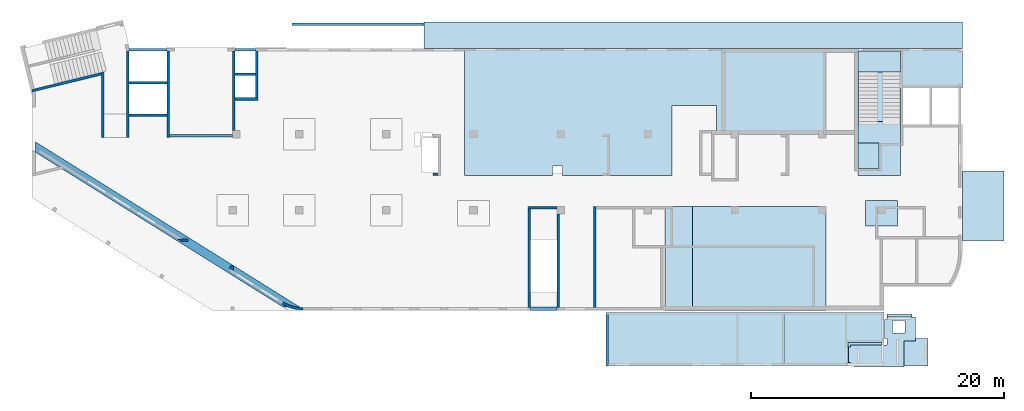
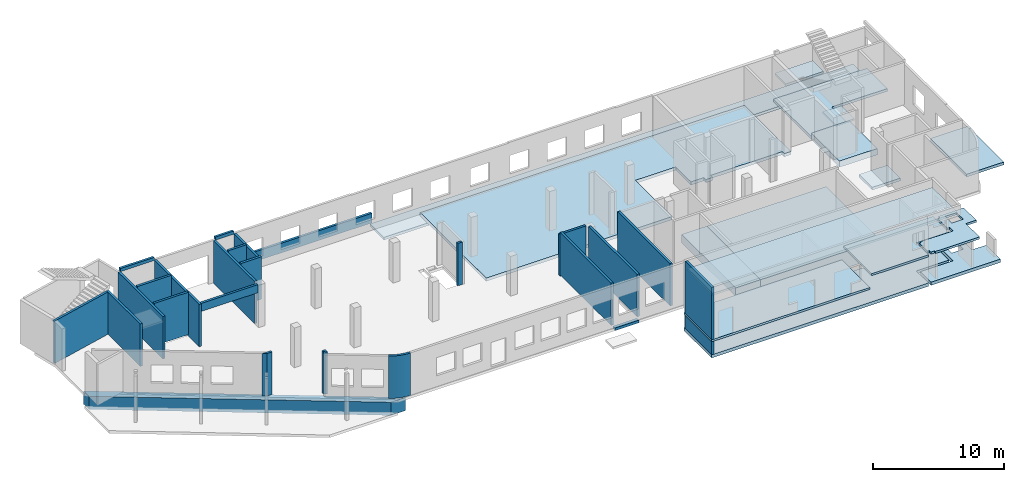
# One storey, part 2 of 8: 25 walls, 16 slabs, 1 opening.
"""IFC4 building model written with IfcOpenShell, lengths in millimetres."""

from ifc_helpers import new_model, entity, si_unit, converted_unit, derived_unit, direction, frame, origin, place, context, subcontext, project, spatial, indexed_curve, outline, extrude, material, type_object, element, save


model = new_model("IFC4")

# Units and contexts
model_context = context("Model", 3, precision=0.01, world=origin(), true_north=direction((6.12303176911189e-17, 1.0)))
plan_context = context("Plan", 3, precision=0.01, world=origin(), true_north=direction((6.12303176911189e-17, 1.0)))
body_context = subcontext(model_context, "Body", "Model", "MODEL_VIEW")
ifc_project = project(units=[si_unit("LENGTHUNIT", "METRE", prefix="MILLI"), si_unit("AREAUNIT", "SQUARE_METRE"), si_unit("VOLUMEUNIT", "CUBIC_METRE"), converted_unit("PLANEANGLEUNIT", "DEGREE", entity("IfcRatioMeasure", 0.0174532925199433), si_unit("PLANEANGLEUNIT", "RADIAN"), dimensions=[0, 0, 0, 0, 0, 0, 0]), si_unit("MASSUNIT", "GRAM", prefix="KILO"), derived_unit("MASSDENSITYUNIT", [(si_unit("MASSUNIT", "GRAM", prefix="KILO"), 1), (si_unit("LENGTHUNIT", "METRE"), -3)]), derived_unit("MOMENTOFINERTIAUNIT", [(si_unit("LENGTHUNIT", "METRE"), 4)]), si_unit("TIMEUNIT", "SECOND"), si_unit("FREQUENCYUNIT", "HERTZ"), si_unit("THERMODYNAMICTEMPERATUREUNIT", "DEGREE_CELSIUS"), derived_unit("THERMALTRANSMITTANCEUNIT", [(si_unit("MASSUNIT", "GRAM", prefix="KILO"), 1), (si_unit("THERMODYNAMICTEMPERATUREUNIT", "KELVIN"), -1), (si_unit("TIMEUNIT", "SECOND"), -3)]), derived_unit("VOLUMETRICFLOWRATEUNIT", [(si_unit("LENGTHUNIT", "METRE"), 3), (si_unit("TIMEUNIT", "SECOND"), -1)]), derived_unit("MASSFLOWRATEUNIT", [(si_unit("MASSUNIT", "GRAM", prefix="KILO"), 1), (si_unit("TIMEUNIT", "SECOND"), -1)]), derived_unit("ROTATIONALFREQUENCYUNIT", [(si_unit("TIMEUNIT", "SECOND"), -1)]), si_unit("ELECTRICCURRENTUNIT", "AMPERE"), si_unit("ELECTRICVOLTAGEUNIT", "VOLT"), si_unit("POWERUNIT", "WATT"), si_unit("FORCEUNIT", "NEWTON", prefix="KILO"), si_unit("ILLUMINANCEUNIT", "LUX"), si_unit("LUMINOUSFLUXUNIT", "LUMEN"), si_unit("LUMINOUSINTENSITYUNIT", "CANDELA"), derived_unit("USERDEFINED", [(si_unit("MASSUNIT", "GRAM", prefix="KILO"), -1), (si_unit("LENGTHUNIT", "METRE"), -2), (si_unit("TIMEUNIT", "SECOND"), 3), (si_unit("LUMINOUSFLUXUNIT", "LUMEN"), 1)]), derived_unit("LINEARVELOCITYUNIT", [(si_unit("LENGTHUNIT", "METRE"), 1), (si_unit("TIMEUNIT", "SECOND"), -1)]), si_unit("PRESSUREUNIT", "PASCAL"), derived_unit("USERDEFINED", [(si_unit("LENGTHUNIT", "METRE"), -2), (si_unit("MASSUNIT", "GRAM", prefix="KILO"), 1), (si_unit("TIMEUNIT", "SECOND"), -2)]), derived_unit("LINEARFORCEUNIT", [(si_unit("MASSUNIT", "GRAM", prefix="KILO"), 1), (si_unit("LENGTHUNIT", "METRE"), 1), (si_unit("TIMEUNIT", "SECOND"), -2), (si_unit("LENGTHUNIT", "METRE"), -1)]), derived_unit("PLANARFORCEUNIT", [(si_unit("MASSUNIT", "GRAM", prefix="KILO"), 1), (si_unit("LENGTHUNIT", "METRE"), 1), (si_unit("TIMEUNIT", "SECOND"), -2), (si_unit("LENGTHUNIT", "METRE"), -2)])], contexts=[model_context, plan_context])

# Site, building, storey
site_placement = place(None, origin())
site = spatial("IfcSite", under=ifc_project, at=site_placement, CompositionType="ELEMENT")
building_placement = place(site_placement, origin())
building = spatial("IfcBuilding", under=site, at=building_placement, CompositionType="ELEMENT")
storey_placement = place(building_placement, origin())
storey = spatial("IfcBuildingStorey", under=building, at=storey_placement, Name="01", CompositionType="ELEMENT", Elevation=0.0)

# Slabs
ifc_material = material()
slab_type_1 = type_object("IfcSlabType", Name=":ADSK_ 25_250", PredefinedType="FLOOR", material=ifc_material)
placement_1 = place(storey_placement, origin())
element("IfcSlab", 1, at=placement_1, inside=storey, type_object=slab_type_1, material=ifc_material, Name=":ADSK_ 25_250", ObjectType=":ADSK_ 25_250", PredefinedType="FLOOR", context=body_context, shape_type="SweptSolid", body=[
    extrude(outline(indexed_curve([(-1049.99999999993, -21305.0), (1050.00000000006, -21305.0), (1049.99999999993, 21305.0), (-1050.00000000007, 21305.0), (-1049.99999999993, -21305.0)], self_intersect=False)), frame((52365.0, 21550.0, -1350.0), z_axis=(0.0, 0.0, -1.0), x_axis=(0.0, 1.0, 0.0)), (0.0, 0.0, 1.0), 250.0),
])
slab_type_2 = type_object("IfcSlabType", Name=": 800", PredefinedType="FLOOR", material=ifc_material)
element("IfcSlab", 2, at=placement_1, inside=storey, type_object=slab_type_2, material=ifc_material, Name=": 800", ObjectType=": 800", PredefinedType="FLOOR", context=body_context, shape_type="SweptSolid", body=[
    extrude(outline(indexed_curve([(-4125.00000000001, -1100.00000000001), (4125.00000000001, -1100.00000000001), (4125.00000000001, 1100.0), (-4125.00000000001, 1100.0), (-4125.00000000001, -1100.00000000001)], self_intersect=False)), frame((51220.0, 3875.0, -150.0), z_axis=(0.0, 0.0, -1.0), x_axis=(0.0, 1.0, 0.0)), (0.0, 0.0, 1.0), 800.0),
])
slab_type_3 = type_object("IfcSlabType", Name=": 1550", PredefinedType="FLOOR", material=ifc_material)
element("IfcSlab", 3, at=placement_1, inside=storey, type_object=slab_type_3, material=ifc_material, Name=": 1550", ObjectType=": 1550", PredefinedType="FLOOR", context=body_context, shape_type="SweptSolid", body=[
    extrude(outline(indexed_curve([(-4125.00000000001, -5275.00000000001), (4125.00000000002, -5275.00000000001), (4125.0, 5275.0), (-4125.00000000002, 5275.0), (-4125.00000000001, -5275.00000000001)], self_intersect=False)), frame((57595.0, 3875.0, -150.0), z_axis=(0.0, 0.0, -1.0), x_axis=(0.0, 1.0, 0.0)), (0.0, 0.0, 1.0), 1550.0),
])
slab_type_4 = type_object("IfcSlabType", Name=":ADSK_ 25_300", PredefinedType="FLOOR", material=ifc_material)
element("IfcSlab", 4, at=placement_1, inside=storey, type_object=slab_type_4, material=ifc_material, Name=":ADSK_ 25_300", ObjectType=":ADSK_ 25_300", PredefinedType="FLOOR", context=body_context, shape_type="SweptSolid", body=[
    extrude(outline(indexed_curve([(-3212.22229326293, -16716.6666666666), (6862.77834610364, -16716.6666666666), (6862.7783461036, 11883.3333333333), (-237.222293262878, 11883.3333333333), (-237.222293262877, 11283.3333333333), (62.7777067369642, 11283.3333333333), (62.7777067369729, 4983.33333333333), (-237.222293262868, 4983.33333333333), (-237.222293262867, 4383.33333333333), (62.777706736974, 4383.33333333333), (62.7777067369764, 3233.33333333334), (2362.777706737, 3233.33333333334), (2362.777706737, -316.666666666659), (-3212.22229326295, -316.666666666658), (-3212.22229326294, -8951.66666666666), (-2452.22229326295, -8951.66666666666), (-2452.22229326295, -9781.66666666666), (-3212.22229326294, -9781.66666666665), (-3212.22229326293, -16716.6666666666)], self_intersect=False)), frame((50986.67, 13637.22, -150.0), z_axis=(0.0, 0.0, -1.0), x_axis=(0.0, 1.0, 0.0)), (0.0, 0.0, 1.0), 300.0),
])
slab_type_5 = type_object("IfcSlabType", Name=":ADSK_ 25_250", PredefinedType="FLOOR", material=ifc_material)
element("IfcSlab", 5, at=placement_1, inside=storey, type_object=slab_type_5, material=ifc_material, Name=":ADSK_ 25_250", ObjectType=":ADSK_ 25_250", PredefinedType="FLOOR", context=body_context, shape_type="SweptSolid", body=[
    extrude(outline(indexed_curve([(-2762.50000000002, -1650.0), (2762.50000000002, -1650.0), (2762.50000000002, 1650.00000000001), (-2762.50000000002, 1650.00000000001), (-2762.50000000002, -1650.0)], self_intersect=False)), frame((75320.0, 8037.5, -1150.0), z_axis=(0.0, 0.0, -1.0), x_axis=(0.0, 1.0, 0.0)), (0.0, 0.0, 1.0), 250.0),
])
slab_type_6 = type_object("IfcSlabType", Name=":ADSK_ 25_250", PredefinedType="FLOOR", material=ifc_material)
element("IfcSlab", 6, at=placement_1, inside=storey, type_object=slab_type_6, material=ifc_material, Name=":ADSK_ 25_250", ObjectType=":ADSK_ 25_250", PredefinedType="FLOOR", context=body_context, shape_type="SweptSolid", body=[
    extrude(outline(indexed_curve([(-2803.33354645554, -3859.99999999998), (2966.66709291113, -3859.99999999998), (2966.66709291112, 4380.0), (-163.333546455577, 4379.99999999999), (-163.333546455569, -520.000000000003), (-2803.33354645555, -519.999999999999), (-2803.33354645554, -3859.99999999998)], self_intersect=False)), frame((69290.0, 17533.33, -480.0), z_axis=(0.0, 0.0, -1.0), x_axis=(0.0, 1.0, 0.0)), (0.0, 0.0, 1.0), 250.0),
])
slab_type_7 = type_object("IfcSlabType", Name=":ADSK_ 25_580", PredefinedType="FLOOR", material=ifc_material)
element("IfcSlab", 7, at=placement_1, inside=storey, type_object=slab_type_7, material=ifc_material, Name=":ADSK_ 25_580", ObjectType=":ADSK_ 25_580", PredefinedType="FLOOR", context=body_context, shape_type="SweptSolid", body=[
    extrude(outline(indexed_curve([(-2152.5, -1669.99999999999), (2152.5, -1669.99999999999), (2152.5, 1669.99999999998), (-2152.5, 1669.99999999998), (-2152.5, -1669.99999999999)], self_intersect=False)), frame((67100.0, 12577.5, -150.0), z_axis=(0.0, 0.0, -1.0), x_axis=(0.0, 1.0, 0.0)), (0.0, 0.0, 1.0), 580.0),
])
slab_type_8 = type_object("IfcSlabType", Name=":ADSK_ 25_250", PredefinedType="FLOOR", material=ifc_material)
element("IfcSlab", 8, at=placement_1, inside=storey, type_object=slab_type_8, material=ifc_material, Name=":ADSK_ 25_250", ObjectType=":ADSK_ 25_250", PredefinedType="FLOOR", context=body_context, shape_type="SweptSolid", body=[
    extrude(outline(indexed_curve([(-999.999999999959, -1250.0), (999.99999999996, -1250.0), (999.99999999996, 1250.0), (-999.999999999959, 1250.0), (-999.999999999959, -1250.0)], self_intersect=False)), frame((67270.0, 7450.0, -400.0), z_axis=(0.0, 0.0, -1.0), x_axis=(0.0, 1.0, 0.0)), (0.0, 0.0, 1.0), 250.0),
])
slab_type_9 = type_object("IfcSlabType", Name=":ADSK_ 25_150", PredefinedType="FLOOR", material=ifc_material)
element("IfcSlab", 9, at=placement_1, inside=storey, type_object=slab_type_9, material=ifc_material, Name=":ADSK_ 25_150", ObjectType=":ADSK_ 25_150", PredefinedType="FLOOR", context=body_context, shape_type="SweptSolid", body=[
    extrude(outline(indexed_curve([(-1023.11069658518, -824.999999999994), (1023.11069658518, -824.999999999994), (1023.11069658518, 825.000000000003), (-1023.11069658518, 825.000000000003), (-1023.11069658518, -824.999999999994)], self_intersect=False)), frame((66255.0, 12006.89, 2880.0), z_axis=(0.0, 0.0, -1.0), x_axis=(0.0, 1.0, 0.0)), (0.0, 0.0, 1.0), 150.0),
])
slab_type_10 = type_object("IfcSlabType", Name=":ADSK_ 25_200", PredefinedType="FLOOR", material=ifc_material)
element("IfcSlab", 10, at=placement_1, inside=storey, type_object=slab_type_10, material=ifc_material, Name=":ADSK_ 25_200", ObjectType=":ADSK_ 25_200", PredefinedType="FLOOR", context=body_context, shape_type="SweptSolid", body=[
    extrude(outline(indexed_curve([(-834.999999999999, -1670.00000000001), (835.000000000001, -1670.00000000001), (835.000000000001, 1670.00000000002), (-834.999999999999, 1670.00000000002), (-834.999999999999, -1670.00000000001)], self_intersect=False)), frame((67100.0, 19465.0, 2070.0), z_axis=(0.0, 0.0, -1.0), x_axis=(0.0, 1.0, 0.0)), (0.0, 0.0, 1.0), 200.0),
])
slab_type_11 = type_object("IfcSlabType", Name="300", PredefinedType="BASESLAB", material=ifc_material)
element("IfcSlab", 11, at=placement_1, inside=storey, type_object=slab_type_11, material=ifc_material, Name="300", ObjectType="300", PredefinedType="BASESLAB", context=body_context, shape_type="SweptSolid", body=[
    extrude(outline(indexed_curve([(-2033.33335672864, -13709.9988838903), (2216.66664327133, -13709.9988838903), (2216.6666432713, 8289.99776778043), (-183.333286542667, 8289.99776778043), (-183.333286542664, 5420.00111610987), (-2033.33335672866, 5420.00111610987), (-2033.33335672864, -13709.9988838903)], self_intersect=False)), frame((59180.0, -2586.67, -2100.0), z_axis=(0.0, 0.0, -1.0), x_axis=(0.0, 1.0, 0.0)), (0.0, 0.0, 1.0), 300.0),
])
slab_type_12 = type_object("IfcSlabType", Name="300", PredefinedType="BASESLAB", material=ifc_material)
element("IfcSlab", 12, at=placement_1, inside=storey, type_object=slab_type_12, material=ifc_material, Name="300", ObjectType="300", PredefinedType="BASESLAB", context=body_context, shape_type="SweptSolid", body=[
    extrude(outline(indexed_curve([(346.250044284976, -3465.00000565502), (1971.25003272099, -3465.00000565502), (1971.25003272101, 2655.00001400014), (-193.750038675896, 2655.00001400014), (-193.750038675899, 1404.99998828339), (-2123.75003833008, 1404.99998828339), (-2123.75003833009, -594.99999662851), (346.250044284985, -594.99999662851), (346.250044284976, -3465.00000565502)], self_intersect=False), holes=[indexed_curve([(-593.75006897793, -165.000012131557), (-1643.75006897793, -165.000012131557), (-1643.75006897793, 884.999987868378), (-593.75006897793, 884.999987868378), (-593.75006897793, -165.000012131557)], self_intersect=False)]), frame((68290.0, -2648.75, -2400.0), z_axis=(0.0, 0.0, 1.0), x_axis=(0.0, -1.0, 0.0)), (0.0, 0.0, 1.0), 300.0),
])
slab_type_13 = type_object("IfcSlabType", Name=":ADSK_ 25_200", PredefinedType="FLOOR", material=ifc_material)
element("IfcSlab", 13, at=placement_1, inside=storey, type_object=slab_type_13, material=ifc_material, Name=":ADSK_ 25_200", ObjectType=":ADSK_ 25_200", PredefinedType="FLOOR", context=body_context, shape_type="SweptSolid", body=[
    extrude(outline(indexed_curve([(-2125.00000000001, -6977.50000000006), (2125.00000000001, -6977.50000000006), (2125.00000000001, 6977.50000000006), (-2125.00000000001, 6977.50000000006), (-2125.00000000001, -6977.50000000006)], self_intersect=False)), frame((52447.5, -2495.0, -700.0), z_axis=(0.0, 0.0, -1.0), x_axis=(0.0, 1.0, 0.0)), (0.0, 0.0, 1.0), 200.0),
])
slab_type_14 = type_object("IfcSlabType", Name=":ADSK_ 25_200", PredefinedType="FLOOR", material=ifc_material)
element("IfcSlab", 14, at=placement_1, inside=storey, type_object=slab_type_14, material=ifc_material, Name=":ADSK_ 25_200", ObjectType=":ADSK_ 25_200", PredefinedType="FLOOR", context=body_context, shape_type="SweptSolid", body=[
    extrude(outline(indexed_curve([(-2033.33335672867, -4306.66555055693), (2216.66664327135, -4306.66555055693), (2216.66664327134, 3588.33110111375), (-183.333286542677, 3588.33110111375), (-183.333286542674, 718.334449443186), (-2033.33335672867, 718.33444944319), (-2033.33335672867, -4306.66555055693)], self_intersect=False)), frame((63881.67, -2586.67, 530.0), z_axis=(0.0, 0.0, -1.0), x_axis=(0.0, 1.0, 0.0)), (0.0, 0.0, 1.0), 200.0),
])
slab_type_15 = type_object("IfcSlabType", Name=":ADSK_ 25_200", PredefinedType="FLOOR", material=ifc_material)
element("IfcSlab", 15, at=placement_1, inside=storey, type_object=slab_type_15, material=ifc_material, Name=":ADSK_ 25_200", ObjectType=":ADSK_ 25_200", PredefinedType="FLOOR", context=body_context, shape_type="SweptSolid", body=[
    extrude(outline(indexed_curve([(2228.33335127655, 305.555637011421), (3128.33332560626, 305.555637011421), (3128.33332560625, 2205.55563701143), (878.333340648085, 2205.55563701143), (878.333340648086, 1990.55550940005), (703.333325144812, 1990.55550940005), (703.333325144817, 490.555510421834), (878.33334064809, 490.555510421834), (878.333340648092, -34.4444462957527), (-1991.66666837842, -34.4444462957521), (-1991.66666837842, -159.444560785931), (-2166.66667485519, -159.444560785931), (-2166.66667485518, -1409.44456078592), (-1991.66666837841, -1409.44456078592), (-1991.66666837841, -1644.44436298856), (-1666.66667171176, -1644.44436298856), (-1666.66667171176, -1744.44436298856), (2228.33335127656, -1744.44436298856), (2228.33335127655, 305.555637011421)], self_intersect=False), holes=[indexed_curve([(2333.32951382663, 1930.55566696699), (2333.32951382663, 930.555666966988), (1333.32951382658, 930.555666966985), (1333.32951382658, 1930.55566696698), (2333.32951382663, 1930.55566696699)], self_intersect=False)]), frame((66816.67, -2960.56, 490.0)), (0.0, 0.0, 1.0), 200.0),
])
slab_type_16 = type_object("IfcSlabType", Name=":ADSK_ 25_200", PredefinedType="FLOOR", material=ifc_material)
element("IfcSlab", 16, at=placement_1, inside=storey, type_object=slab_type_16, material=ifc_material, Name=":ADSK_ 25_200", ObjectType=":ADSK_ 25_200", PredefinedType="FLOOR", context=body_context, shape_type="SweptSolid", body=[
    extrude(outline(indexed_curve([(-1925.00000000002, -10799.9983258354), (1925.00000000002, -10799.9983258354), (1925.00000000002, 10799.9983258354), (-1925.00000000002, 10799.9983258354), (-1925.00000000002, -10799.9983258354)], self_intersect=False)), frame((56470.0, -2495.0, 3430.0), z_axis=(0.0, 0.0, -1.0), x_axis=(0.0, 1.0, 0.0)), (0.0, 0.0, 1.0), 200.0),
])

# Walls
wall_type_1 = type_object("IfcWallType", Name=":ADSK_ 25_200", PredefinedType="STANDARD")
wall_1_placement = place(storey_placement, frame((41670.0, 7400.0, 0.0), z_axis=(0.0, 0.0, 1.0), x_axis=(0.0, -1.0, 0.0)))
element("IfcWall", 17, at=wall_1_placement, inside=storey, type_object=wall_type_1, material=ifc_material, Name=":ADSK_ 25_200", ObjectType=":ADSK_ 25_200", PredefinedType="NOTDEFINED", context=body_context, shape_type="SweptSolid", body=[
    extrude(outline(indexed_curve([(7399.9999999999, 100.000000000003), (-1.17863088903232e-13, 100.000000000003), (1.17863088903232e-13, -100.000000000003), (7399.9999999999, -100.000000000003), (7399.9999999999, 100.000000000003)], self_intersect=False)), origin(), (0.0, 0.0, 1.0), 3950.0),
])
wall_2_placement = place(storey_placement, frame((41570.0, 7900.0, -150.0), z_axis=(0.0, 0.0, 1.0), x_axis=(-1.0, 0.0, 0.0)))
element("IfcWall", 18, at=wall_2_placement, inside=storey, type_object=wall_type_1, material=ifc_material, Name=":ADSK_ 25_200", ObjectType=":ADSK_ 25_200", PredefinedType="NOTDEFINED", context=body_context, shape_type="SweptSolid", body=[
    extrude(outline(indexed_curve([(2300.00000000001, 100.0), (-3.29568256742987e-13, 100.0), (3.29568256742987e-13, -100.0), (2300.00000000001, -100.0), (2300.00000000001, 100.0)], self_intersect=False)), origin(), (0.0, 0.0, 1.0), 3900.0),
])
wall_3_placement = place(storey_placement, frame((39370.0, 7800.0, 0.0), z_axis=(0.0, 0.0, 1.0), x_axis=(0.0, -1.0, 0.0)))
element("IfcWall", 19, at=wall_3_placement, inside=storey, type_object=wall_type_1, material=ifc_material, Name=":ADSK_ 25_200", ObjectType=":ADSK_ 25_200", PredefinedType="NOTDEFINED", context=body_context, shape_type="SweptSolid", body=[
    extrude(outline(indexed_curve([(7799.9999999999, 100.000000000003), (-1.08967761438837e-13, 100.000000000003), (1.08967761438837e-13, -100.000000000003), (7799.9999999999, -100.000000000003), (7799.9999999999, 100.000000000003)], self_intersect=False)), origin(), (0.0, 0.0, 1.0), 3950.0),
])
wall_4_placement = place(storey_placement, frame((44570.0, 0.0, 0.0), z_axis=(0.0, 0.0, 1.0), x_axis=(0.0, 1.0, 0.0)))
element("IfcWall", 20, at=wall_4_placement, inside=storey, type_object=wall_type_1, material=ifc_material, Name=":ADSK_ 25_200", ObjectType=":ADSK_ 25_200", PredefinedType="NOTDEFINED", context=body_context, shape_type="SweptSolid", body=[
    extrude(outline(indexed_curve([(7999.9999999999, 100.000000000007), (-3.96878629442861e-20, 100.000000000003), (3.96878629442861e-20, -100.000000000003), (7999.9999999999, -99.9999999999995), (7999.9999999999, 100.000000000007)], self_intersect=False)), origin(), (0.0, 0.0, 1.0), 3950.0),
])
wall_5_placement = place(storey_placement, frame((32170.0, 10525.0, 0.0), z_axis=(0.0, 0.0, 1.0), x_axis=(-1.0, 0.0, 0.0)))
element("IfcWall", 21, at=wall_5_placement, inside=storey, type_object=wall_type_1, material=ifc_material, Name=":ADSK_ 25_200", ObjectType=":ADSK_ 25_200", PredefinedType="NOTDEFINED", context=body_context, shape_type="SweptSolid", body=[
    extrude(outline(indexed_curve([(399.999999999987, 100.0), (-3.60955709766139e-13, 100.000000000001), (3.60955709766139e-13, -100.000000000001), (399.999999999987, -100.000000000002), (399.999999999987, 100.0)], self_intersect=False)), origin(), (0.0, 0.0, 1.0), 3950.0),
])
wall_6_placement = place(storey_placement, frame((5600.0, 18641.06, -150.0), z_axis=(0.0, 0.0, 1.0), x_axis=(0.0, -1.0, 0.0)))
element("IfcWall", 22, at=wall_6_placement, inside=storey, type_object=wall_type_1, material=ifc_material, Name=":ADSK_ 25_200", ObjectType=":ADSK_ 25_200", PredefinedType="NOTDEFINED", context=body_context, shape_type="SweptSolid", body=[
    extrude(outline(indexed_curve([(5191.05764338694, -99.9999999999995), (5191.05764338694, 100.0), (-2.17498395156585e-13, 100.0), (48.7521159583305, -99.9999999999999), (254.608300734048, -99.9999999999994), (5191.05764338694, -99.9999999999995)], self_intersect=False)), origin(), (0.0, 0.0, 1.0), 3950.0),
])
wall_7_placement = place(storey_placement, frame((5523.68, 18495.15, -150.0), z_axis=(0.0, 0.0, 1.0), x_axis=(-0.971552058141474, -0.236826092990334, 0.0)))
element("IfcWall", 23, at=wall_7_placement, inside=storey, type_object=wall_type_1, material=ifc_material, Name=":ADSK_ 25_200", ObjectType=":ADSK_ 25_200", PredefinedType="NOTDEFINED", context=body_context, shape_type="SweptSolid", body=[
    extrude(outline(indexed_curve([(5661.04508133225, -100.0), (5709.79719729058, 99.9999999999997), (5401.01292012701, 100.0), (48.7521159583298, 99.9999999999999), (2.41107134257845e-13, -100.0), (5458.73710852648, -100.000000000001), (5661.04508133225, -100.0)], self_intersect=False)), origin(), (0.0, 0.0, 1.0), 3950.0),
])
wall_8_placement = place(storey_placement, frame((7600.0, 20297.52, -150.0), z_axis=(0.0, 0.0, 1.0), x_axis=(0.0, -1.0, 0.0)))
element("IfcWall", 24, at=wall_8_placement, inside=storey, type_object=wall_type_1, material=ifc_material, Name=":ADSK_ 25_200", ObjectType=":ADSK_ 25_200", PredefinedType="NOTDEFINED", context=body_context, shape_type="SweptSolid", body=[
    extrude(outline(indexed_curve([(6847.52486422499, -100.0), (6847.52486422499, 99.9999999999998), (5097.52422485856, 99.9999999999998), (-1.86299721169617e-13, 100.0), (24.0243306802184, -100.0), (6847.52486422499, -100.0)], self_intersect=False)), origin(), (0.0, 0.0, 1.0), 3950.0),
])
wall_9_placement = place(storey_placement, frame((10800.0, 20300.0, -150.0), z_axis=(0.0, 0.0, 1.0), x_axis=(0.0, -1.0, 0.0)))
element("IfcWall", 25, at=wall_9_placement, inside=storey, type_object=wall_type_1, material=ifc_material, Name=":ADSK_ 25_200", ObjectType=":ADSK_ 25_200", PredefinedType="NOTDEFINED", context=body_context, shape_type="SweptSolid", body=[
    extrude(outline(indexed_curve([(6849.99999999998, 99.9999999999997), (-1.68937704985105e-13, 99.9999999999989), (1.68937704985105e-13, -99.9999999999989), (6849.99999999998, -99.9999999999982), (6849.99999999998, 99.9999999999997)], self_intersect=False)), origin(), (0.0, 0.0, 1.0), 3950.0),
])
for number, where, z_axis, x_axis, name in (
    (26, (10700.0, 17800.0, 0.0), (0.0, 0.0, 1.0), (-1.0, 0.0, 0.0), ":ADSK_ 25_200"),
    (27, (10700.0, 15200.0, 0.0), (0.0, 0.0, 1.0), (-1.0, 0.0, 0.0), ":ADSK_ 25_200"),
):
    element("IfcWall", number, at=place(storey_placement, frame(where, z_axis=z_axis, x_axis=x_axis)), inside=storey, type_object=wall_type_1, material=ifc_material, Name=name, ObjectType=":ADSK_ 25_200", PredefinedType="NOTDEFINED", context=body_context, shape_type="SweptSolid", body=[
        extrude(outline(indexed_curve([(3000.0, 99.9999999999989), (-2.88764567812902e-13, 99.9999999999989), (2.88764567812902e-13, -99.9999999999989), (3000.00000000001, -99.9999999999989), (3000.0, 99.9999999999989)], self_intersect=False)), origin(), (0.0, 0.0, 1.0), 3950.0),
    ])
wall_10_placement = place(storey_placement, frame((16000.0, 20300.0, -150.0), z_axis=(0.0, 0.0, 1.0), x_axis=(0.0, -1.0, 0.0)))
element("IfcWall", 28, at=wall_10_placement, inside=storey, type_object=wall_type_1, material=ifc_material, Name=":ADSK_ 25_200", ObjectType=":ADSK_ 25_200", PredefinedType="NOTDEFINED", context=body_context, shape_type="SweptSolid", body=[
    extrude(outline(indexed_curve([(6300.00000000003, 99.9999999999989), (-1.37506937053763e-13, 99.9999999999989), (1.37506937053763e-13, -99.9999999999989), (6300.00000000003, -99.9999999999989), (6300.00000000003, 99.9999999999989)], self_intersect=False)), origin(), (0.0, 0.0, 1.0), 3950.0),
])
wall_11_placement = place(storey_placement, frame((17825.0, 20300.0, -150.0), z_axis=(0.0, 0.0, 1.0), x_axis=(0.0, -1.0, 0.0)))
element("IfcWall", 29, at=wall_11_placement, inside=storey, type_object=wall_type_1, material=ifc_material, Name=":ADSK_ 25_200", ObjectType=":ADSK_ 25_200", PredefinedType="NOTDEFINED", context=body_context, shape_type="SweptSolid", body=[
    extrude(outline(indexed_curve([(3700.00000000023, 99.9999999999984), (4.24739052372736e-13, 99.9999999999989), (-4.24739052372736e-13, -99.9999999999989), (3700.00000000023, -99.9999999999995), (3700.00000000023, 99.9999999999984)], self_intersect=False)), origin(), (0.0, 0.0, 1.0), 3950.0),
])
wall_12_placement = place(storey_placement, frame((17725.0, 18450.0, 0.0), z_axis=(0.0, 0.0, 1.0), x_axis=(-1.0, 0.0, 0.0)))
element("IfcWall", 30, at=wall_12_placement, inside=storey, type_object=wall_type_1, material=ifc_material, Name=":ADSK_ 25_200", ObjectType=":ADSK_ 25_200", PredefinedType="NOTDEFINED", context=body_context, shape_type="SweptSolid", body=[
    extrude(outline(indexed_curve([(1624.99999999999, 99.9999999999989), (-2.66551908750371e-13, 99.9999999999989), (2.66551908750371e-13, -99.9999999999989), (1624.99999999999, -99.9999999999989), (1624.99999999999, 99.9999999999989)], self_intersect=False)), origin(), (0.0, 0.0, 1.0), 3950.0),
])
wall_13_placement = place(storey_placement, frame((17925.0, 16500.0, 0.0), z_axis=(0.0, 0.0, 1.0), x_axis=(-1.0, 0.0, 0.0)))
element("IfcWall", 31, at=wall_13_placement, inside=storey, type_object=wall_type_1, material=ifc_material, Name=":ADSK_ 25_200", ObjectType=":ADSK_ 25_200", PredefinedType="NOTDEFINED", context=body_context, shape_type="SweptSolid", body=[
    extrude(outline(indexed_curve([(1825.00000000001, 99.9999999999995), (-2.66551908750371e-13, 99.9999999999989), (2.66551908750371e-13, -99.9999999999989), (1825.00000000001, -99.9999999999984), (1825.00000000001, 99.9999999999995)], self_intersect=False)), origin(), (0.0, 0.0, 1.0), 3950.0),
])
wall_14_placement = place(storey_placement, frame((15900.0, 13600.0, 3050.0), z_axis=(0.0, 0.0, 1.0), x_axis=(-1.0, 0.0, 0.0)))
element("IfcWall", 32, at=wall_14_placement, inside=storey, type_object=wall_type_1, material=ifc_material, Name=":ADSK_ 25_200", ObjectType=":ADSK_ 25_200", PredefinedType="NOTDEFINED", context=body_context, shape_type="SweptSolid", body=[
    extrude(outline(indexed_curve([(4999.99999999999, 99.9999999999989), (-3.03202796203547e-13, 99.9999999999989), (3.03202796203547e-13, -99.9999999999989), (4999.99999999999, -99.9999999999989), (4999.99999999999, 99.9999999999989)], self_intersect=False)), origin(), (0.0, 0.0, 1.0), 750.000000000001),
])
wall_15_placement = place(storey_placement, frame((21465.0, -100.0, -150.0)))
element("IfcWall", 33, at=wall_15_placement, inside=storey, type_object=wall_type_1, material=ifc_material, Name=":ADSK_ 25_200", ObjectType=":ADSK_ 25_200", PredefinedType="NOTDEFINED", context=body_context, shape_type="SweptSolid", body=[
    extrude(outline(indexed_curve([(-1669.7311591292, 370.165232796515), (-1503.53564298382, 275.220261635061), (-1331.96118607575, 190.381571616725), (-1155.62145828086, 115.952573238706), (-975.147407258616, 52.1995580227518), (-791.184711518204, -0.649408149811444), (-604.391528471895, -42.4052699025555), (-415.436139881236, -72.9186585351565), (-224.989102437801, -92.0805293177081), (-125.0800800656, -97.5545301950318), (-25.0252657996871, -99.9011362110873), (-12.5071092046703, -99.9755580659273), (-2.16573425859679e-11, -100.0), (2.16573425859679e-11, 100.0), (-164.508224209949, 104.513888503692), (-328.521400565239, 118.041970555148), (-491.545970938373, 140.54353665167), (-653.091352173336, 171.950873752911), (-812.671412377343, 212.169469046957), (-969.805933817615, 261.078294363853), (-1124.02205802091, 318.530170380714), (-1274.85570872713, 384.352209522427), (-1421.85298841503, 458.346336225146), (-1564.57154419737, 540.289882996962), (-1669.7311591292, 370.165232796515)], self_intersect=False)), origin(), (0.0, 0.0, 1.0), 3950.0),
])
wall_16_placement = place(storey_placement, frame((12375.0, 5300.0, -150.0), z_axis=(0.0, 0.0, 1.0), x_axis=(-1.0, 0.0, 0.0)))
element("IfcWall", 34, at=wall_16_placement, inside=storey, type_object=wall_type_1, material=ifc_material, Name=":ADSK_ 25_200", ObjectType=":ADSK_ 25_200", PredefinedType="NOTDEFINED", context=body_context, shape_type="SweptSolid", body=[
    extrude(outline(indexed_curve([(789.343084396992, -100.0), (469.26993203138, 99.9999999999996), (-3.81254187175444e-13, 100.0), (3.81254187175444e-13, -100.0), (411.921804041392, -99.9999999999995), (789.343084396992, -100.0)], self_intersect=False)), origin(), (0.0, 0.0, 1.0), 3950.0),
])
wall_17_placement = place(storey_placement, frame((20590.0, 22400.0, -1075.0)))
element("IfcWall", 35, at=wall_17_placement, inside=storey, type_object=wall_type_1, material=ifc_material, Name=":ADSK_ 25_200", ObjectType=":ADSK_ 25_200", PredefinedType="NOTDEFINED", context=body_context, shape_type="SweptSolid", body=[
    extrude(outline(indexed_curve([(10470.0, 99.9999999999994), (-3.35772753270816e-13, 99.9999999999989), (3.35772753270816e-13, -99.9999999999989), (10470.0, -99.9999999999984), (10470.0, 99.9999999999994)], self_intersect=False)), origin(), (0.0, 0.0, 1.0), 900.0),
])
wall_18_placement = place(storey_placement, frame((16100.0, 20400.0, 3750.0)))
element("IfcWall", 36, at=wall_18_placement, inside=storey, type_object=wall_type_1, material=ifc_material, Name=":ADSK_ 25_200", ObjectType=":ADSK_ 25_200", PredefinedType="NOTDEFINED", context=body_context, shape_type="SweptSolid", body=[
    extrude(outline(indexed_curve([(1624.99999999998, 99.9999999999989), (-2.66551908750373e-13, 99.9999999999989), (2.66551908750373e-13, -99.9999999999989), (1624.99999999998, -99.9999999999989), (1624.99999999998, 99.9999999999989)], self_intersect=False)), origin(), (0.0, 0.0, 1.0), 299.999999999999),
])
wall_19_placement = place(storey_placement, frame((7700.0, 20400.0, 3750.0)))
element("IfcWall", 37, at=wall_19_placement, inside=storey, type_object=wall_type_1, material=ifc_material, Name=":ADSK_ 25_200", ObjectType=":ADSK_ 25_200", PredefinedType="NOTDEFINED", context=body_context, shape_type="SweptSolid", body=[
    extrude(outline(indexed_curve([(2999.99999999997, 99.9999999999989), (-2.88764567812905e-13, 99.9999999999989), (2.88764567812905e-13, -99.9999999999989), (2999.99999999997, -99.9999999999989), (2999.99999999997, 99.9999999999989)], self_intersect=False)), origin(), (0.0, 0.0, 1.0), 299.999999999999),
])

# Wall, opening
placement_2 = place(storey_placement, frame((45570.0, -4620.0, -2100.0), z_axis=(0.0, 0.0, 1.0), x_axis=(0.0, 1.0, 0.0)))
wall_20 = element("IfcWall", 38, at=placement_2, inside=storey, type_object=wall_type_1, material=ifc_material, Name=":ADSK_ 25_200", ObjectType=":ADSK_ 25_200", PredefinedType="NOTDEFINED", context=body_context, shape_type="SweptSolid", body=[
    extrude(outline(indexed_curve([(4050.00000000003, 100.000000000003), (0.0, 100.000000000003), (0.0, -100.000000000003), (4050.00000000003, -100.000000000003), (4050.00000000003, 100.000000000003)], self_intersect=False)), origin(), (0.0, 0.0, 1.0), 6280.0),
])
element("IfcOpeningElement", 39, at=placement_2, cuts=wall_20, Name=":ADSK_ 25_200:1", PredefinedType="OPENING", context=body_context, shape_type="SweptSolid", body=[
    extrude(outline(indexed_curve([(-2025.00000000002, -100.000000000003), (2025.00000000002, -100.000000000003), (2025.00000000002, 99.9999999999946), (-2025.00000000002, 99.9999999999946), (-2025.00000000002, -100.000000000003)], self_intersect=False)), frame((2025.0, 0.0, 1200.0)), (0.0, 0.0, 1.0), 200.0),
])

# Walls
wall_type_2 = type_object("IfcWallType", Name=":ADSK_ 25_300", PredefinedType="STANDARD")
wall_21_placement = place(storey_placement, frame((39470.0, -100.0, -400.0)))
element("IfcWall", 40, at=wall_21_placement, inside=storey, type_object=wall_type_2, material=ifc_material, Name=":ADSK_ 25_300", ObjectType=":ADSK_ 25_300", PredefinedType="NOTDEFINED", context=body_context, shape_type="SweptSolid", body=[
    extrude(outline(indexed_curve([(2100.00000000002, 150.0), (-1.04267903610388e-12, 150.0), (1.04267903610388e-12, -150.0), (2100.00000000002, -150.0), (2100.00000000002, 150.0)], self_intersect=False)), origin(), (0.0, 0.0, 1.0), 250.0),
])
wall_type_3 = type_object("IfcWallType", Name=":ADSK_ 25_700", PredefinedType="STANDARD")
wall_22_placement = place(storey_placement, frame((21000.05, -246.82, -1620.0), z_axis=(0.0, 0.0, 1.0), x_axis=(-0.848052743777574, 0.529911826412026, 0.0)))
element("IfcWall", 41, at=wall_22_placement, inside=storey, type_object=wall_type_3, material=ifc_material, Name=":ADSK_ 25_700", ObjectType=":ADSK_ 25_700", PredefinedType="NOTDEFINED", context=body_context, shape_type="SweptSolid", body=[
    extrude(outline(indexed_curve([(24627.6218261242, -350.000000000003), (24190.2218162662, 350.000000000001), (1120.25603327965, 350.000000000001), (-1.35358391162299e-13, -350.0), (24627.6218261242, -350.000000000003)], self_intersect=False)), origin(), (0.0, 0.0, 1.0), 1220.0),
])
wall_type_4 = type_object("IfcWallType", Name=":ADSK_ 25_270", PredefinedType="STANDARD")
wall_23_placement = place(storey_placement, frame((15815.0, 3270.0, 0.0), z_axis=(0.0, 0.0, 1.0), x_axis=(0.0, -1.0, 0.0)))
element("IfcWall", 42, at=wall_23_placement, inside=storey, type_object=wall_type_4, material=ifc_material, Name=":ADSK_ 25_270", ObjectType=":ADSK_ 25_270", PredefinedType="NOTDEFINED", context=body_context, shape_type="SweptSolid", body=[
    extrude(outline(indexed_curve([(192.545191041583, -135.0), (361.256623415384, 135.0), (0.0, 135.0), (0.0, -135.0), (192.545191041583, -135.0)], self_intersect=False)), origin(), (0.0, 0.0, 1.0), 3950.0),
])

save(model, "model.ifc")
